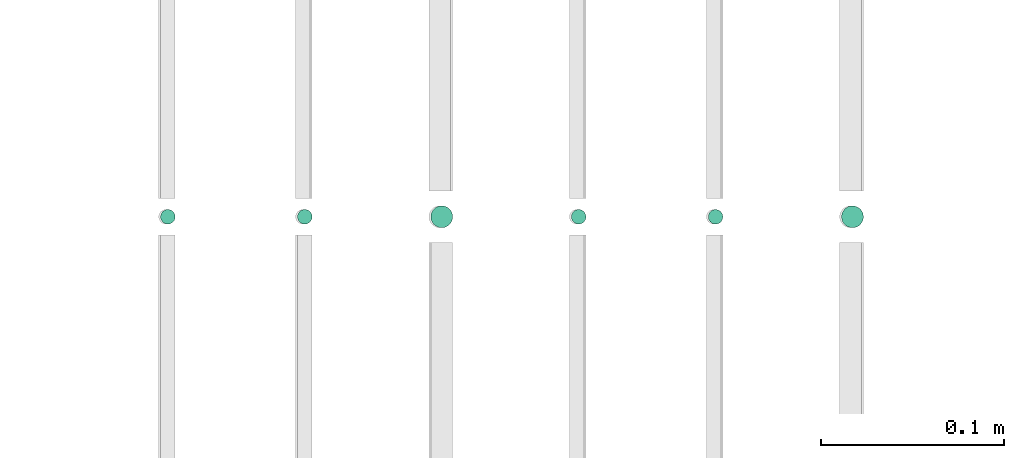
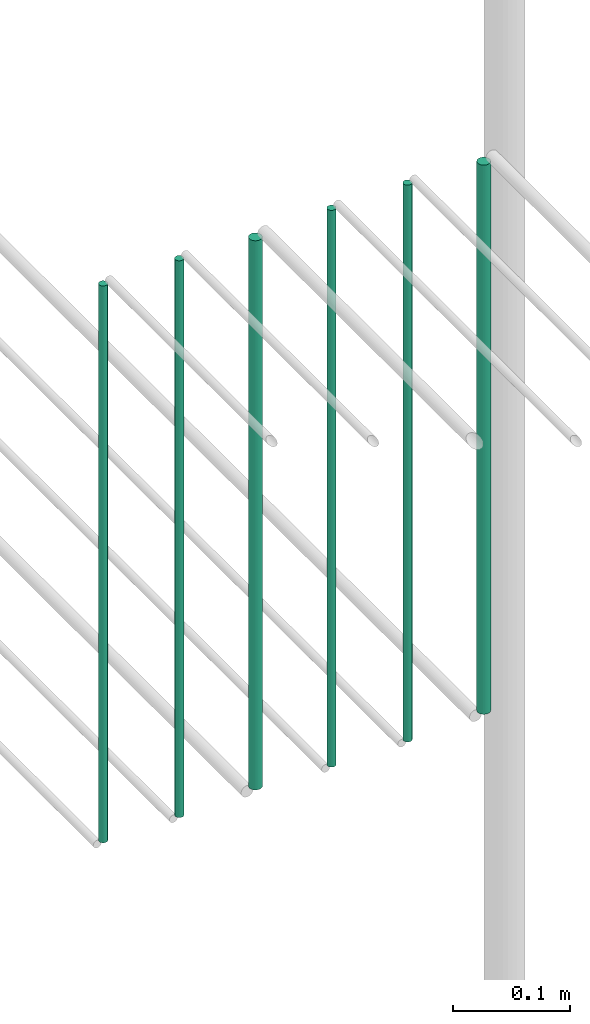
# One storey, part 212 of 331: 6 flow segments.
"""IFC2X3 building model written with IfcOpenShell, lengths in millimetres."""

from ifc_helpers import new_model, entity, si_unit, converted_unit, derived_unit, direction, frame, origin, origin_2d_with_axis, place, context, subcontext, project, spatial, circle, extrude, type_object, element, save


model = new_model("IFC2X3")

# Units and contexts
model_context = context("Model", 3, precision=0.01, world=origin(), true_north=direction((6.12303176911189e-17, 1.0)))
body_context = subcontext(model_context, "Body", "Model", "MODEL_VIEW")
ifc_project = project(units=[si_unit("LENGTHUNIT", "METRE", prefix="MILLI"), si_unit("AREAUNIT", "SQUARE_METRE"), si_unit("VOLUMEUNIT", "CUBIC_METRE"), converted_unit("PLANEANGLEUNIT", "DEGREE", entity("IfcRatioMeasure", 0.0174532925199433), si_unit("PLANEANGLEUNIT", "RADIAN"), dimensions=[0, 0, 0, 0, 0, 0, 0]), si_unit("MASSUNIT", "GRAM", prefix="KILO"), derived_unit("MASSDENSITYUNIT", [(si_unit("MASSUNIT", "GRAM", prefix="KILO"), 1), (si_unit("LENGTHUNIT", "METRE"), -3)]), derived_unit("MOMENTOFINERTIAUNIT", [(si_unit("LENGTHUNIT", "METRE"), 4)]), si_unit("TIMEUNIT", "SECOND"), si_unit("FREQUENCYUNIT", "HERTZ"), si_unit("THERMODYNAMICTEMPERATUREUNIT", "DEGREE_CELSIUS"), derived_unit("THERMALTRANSMITTANCEUNIT", [(si_unit("MASSUNIT", "GRAM", prefix="KILO"), 1), (si_unit("THERMODYNAMICTEMPERATUREUNIT", "KELVIN"), -1), (si_unit("TIMEUNIT", "SECOND"), -3)]), derived_unit("VOLUMETRICFLOWRATEUNIT", [(si_unit("LENGTHUNIT", "METRE"), 3), (si_unit("TIMEUNIT", "SECOND"), -1)]), derived_unit("MASSFLOWRATEUNIT", [(si_unit("MASSUNIT", "GRAM", prefix="KILO"), 1), (si_unit("TIMEUNIT", "SECOND"), -1)]), derived_unit("ROTATIONALFREQUENCYUNIT", [(si_unit("TIMEUNIT", "SECOND"), -1)]), si_unit("ELECTRICCURRENTUNIT", "AMPERE"), si_unit("ELECTRICVOLTAGEUNIT", "VOLT"), si_unit("POWERUNIT", "WATT"), si_unit("FORCEUNIT", "NEWTON", prefix="KILO"), si_unit("ILLUMINANCEUNIT", "LUX"), si_unit("LUMINOUSFLUXUNIT", "LUMEN"), si_unit("LUMINOUSINTENSITYUNIT", "CANDELA"), derived_unit("USERDEFINED", [(si_unit("MASSUNIT", "GRAM", prefix="KILO"), -1), (si_unit("LENGTHUNIT", "METRE"), -2), (si_unit("TIMEUNIT", "SECOND"), 3), (si_unit("LUMINOUSFLUXUNIT", "LUMEN"), 1)]), derived_unit("LINEARVELOCITYUNIT", [(si_unit("LENGTHUNIT", "METRE"), 1), (si_unit("TIMEUNIT", "SECOND"), -1)]), si_unit("PRESSUREUNIT", "PASCAL"), derived_unit("USERDEFINED", [(si_unit("LENGTHUNIT", "METRE"), -2), (si_unit("MASSUNIT", "GRAM", prefix="KILO"), 1), (si_unit("TIMEUNIT", "SECOND"), -2)]), derived_unit("LINEARFORCEUNIT", [(si_unit("MASSUNIT", "GRAM", prefix="KILO"), 1), (si_unit("LENGTHUNIT", "METRE"), 1), (si_unit("TIMEUNIT", "SECOND"), -2), (si_unit("LENGTHUNIT", "METRE"), -1)]), derived_unit("PLANARFORCEUNIT", [(si_unit("MASSUNIT", "GRAM", prefix="KILO"), 1), (si_unit("LENGTHUNIT", "METRE"), 1), (si_unit("TIMEUNIT", "SECOND"), -2), (si_unit("LENGTHUNIT", "METRE"), -2)])], contexts=[model_context])

# Site, building, storey
site_placement = place(None, frame((0.0, -0.00077364408347762, 0.0)))
site = spatial("IfcSite", under=ifc_project, at=site_placement, CompositionType="ELEMENT")
building_placement = place(site_placement, origin())
building = spatial("IfcBuilding", under=site, at=building_placement, CompositionType="ELEMENT")
storey_placement = place(building_placement, origin())
storey = spatial("IfcBuildingStorey", under=building, at=storey_placement, CompositionType="ELEMENT", Elevation=0.0)

# Flow segments
pipe_segment_type = type_object("IfcPipeSegmentType", PredefinedType="NOTDEFINED")
flow_segment_1_placement = place(storey_placement, frame((61865.5225183915, 5638.02529159143, 14560.0)))
element("IfcFlowSegment", 1, at=flow_segment_1_placement, inside=storey, type_object=pipe_segment_type, context=body_context, shape_type="SweptSolid", body=[
    extrude(circle(Radius=4.0, at=origin_2d_with_axis()), frame((5.59527223591499, 5.59527223591607, 0.0), z_axis=(0.0, 0.0, 1.0), x_axis=(-1.0, 0.0, 0.0)), (0.0, 0.0, 1.0), 580.000000000015),
])
flow_segment_2_placement = place(storey_placement, frame((61940.5225183915, 5638.02529159143, 14560.0)))
element("IfcFlowSegment", 2, at=flow_segment_2_placement, inside=storey, type_object=pipe_segment_type, context=body_context, shape_type="SweptSolid", body=[
    extrude(circle(Radius=4.0, at=origin_2d_with_axis()), frame((5.59527223591499, 5.59527223591607, 0.0), z_axis=(0.0, 0.0, 1.0), x_axis=(-1.0, 0.0, 0.0)), (0.0, 0.0, 1.0), 580.000000000007),
])
flow_segment_3_placement = place(storey_placement, frame((62013.5225183915, 5636.02529159143, 14564.0)))
element("IfcFlowSegment", 3, at=flow_segment_3_placement, inside=storey, type_object=pipe_segment_type, context=body_context, shape_type="SweptSolid", body=[
    extrude(circle(Radius=6.0, at=origin_2d_with_axis()), frame((7.59527223591454, 7.59527223591562, 0.0), z_axis=(0.0, 0.0, 1.0), x_axis=(-1.0, 0.0, 0.0)), (0.0, 0.0, 1.0), 572.000000000002),
])
flow_segment_4_placement = place(storey_placement, frame((62090.5225183915, 5638.02529159143, 14560.0)))
element("IfcFlowSegment", 4, at=flow_segment_4_placement, inside=storey, type_object=pipe_segment_type, context=body_context, shape_type="SweptSolid", body=[
    extrude(circle(Radius=4.0, at=origin_2d_with_axis()), frame((5.59527223591499, 5.59527223591607, 0.0), z_axis=(0.0, 0.0, 1.0), x_axis=(-1.0, 0.0, 0.0)), (0.0, 0.0, 1.0), 580.000000000015),
])
flow_segment_5_placement = place(storey_placement, frame((62165.5225183915, 5638.02529159143, 14560.0)))
element("IfcFlowSegment", 5, at=flow_segment_5_placement, inside=storey, type_object=pipe_segment_type, context=body_context, shape_type="SweptSolid", body=[
    extrude(circle(Radius=4.0, at=origin_2d_with_axis()), frame((5.59527223591499, 5.59527223591607, 0.0), z_axis=(0.0, 0.0, 1.0), x_axis=(-1.0, 0.0, 0.0)), (0.0, 0.0, 1.0), 580.0),
])
flow_segment_6_placement = place(storey_placement, frame((62238.5225183915, 5636.02529159145, 14564.0)))
element("IfcFlowSegment", 6, at=flow_segment_6_placement, inside=storey, type_object=pipe_segment_type, context=body_context, shape_type="SweptSolid", body=[
    extrude(circle(Radius=6.0, at=origin_2d_with_axis()), frame((7.59527223591454, 7.59527223591562, 0.0), z_axis=(0.0, 0.0, 1.0), x_axis=(-1.0, 0.0, 0.0)), (0.0, 0.0, 1.0), 572.000000000011),
])

save(model, "model.ifc")
